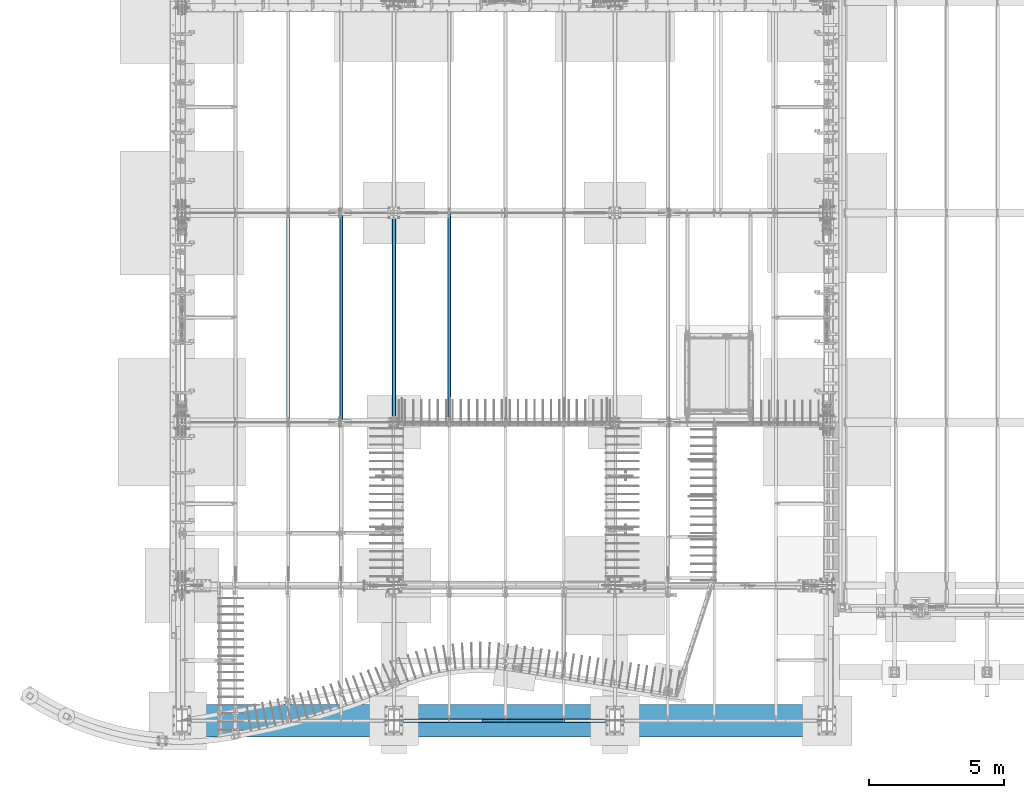
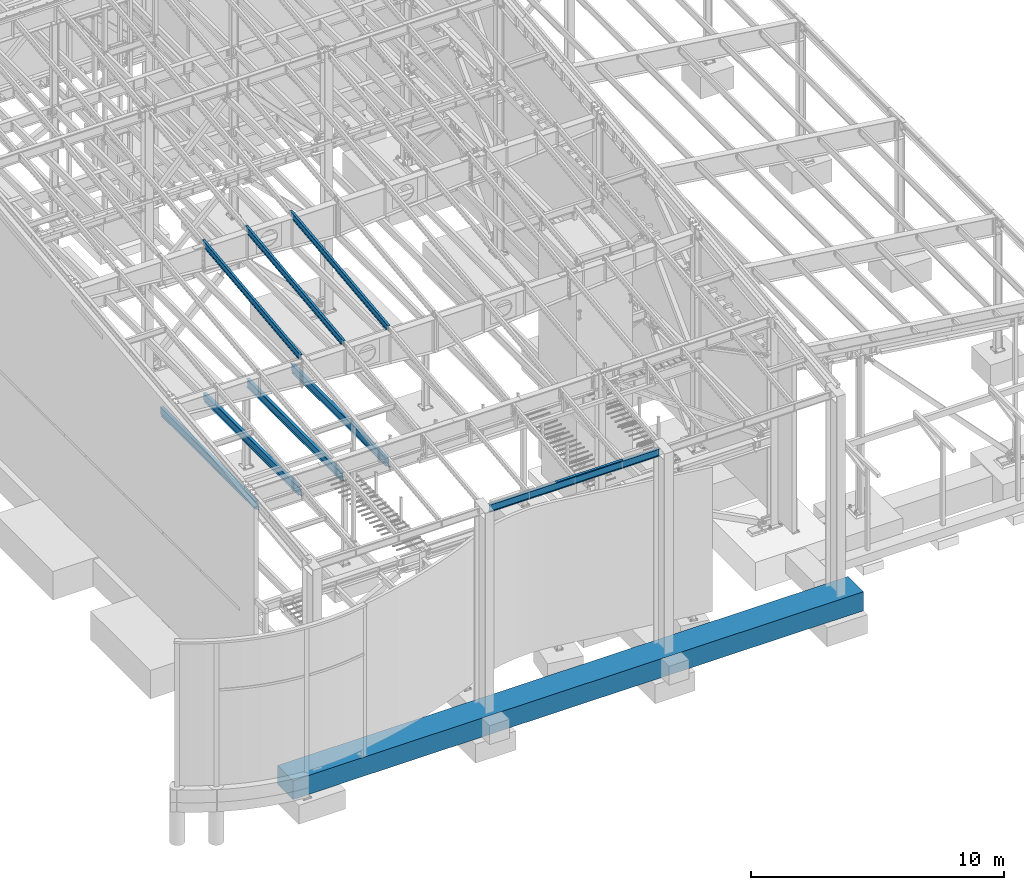
# One storey, part 711 of 1179: 10 beams, 9 elements without a shape of their own.
"""IFC2X3 building model written with IfcOpenShell, lengths in millimetres."""

from ifc_helpers import new_model, si_unit, frame, origin_with_axes, place, context, subcontext, project, spatial, faceted_brep, material, type_object, element, aggregate, save


model = new_model("IFC2X3")

# Units and contexts
model_context = context("Model", 3, precision=1e-05, world=origin_with_axes())
body_context = subcontext(model_context, "Body", "Model", "MODEL_VIEW")
ifc_project = project(units=[si_unit("LENGTHUNIT", "METRE", prefix="MILLI"), si_unit("AREAUNIT", "SQUARE_METRE"), si_unit("VOLUMEUNIT", "CUBIC_METRE"), si_unit("MASSUNIT", "GRAM", prefix="KILO"), si_unit("TIMEUNIT", "SECOND"), si_unit("PLANEANGLEUNIT", "RADIAN"), si_unit("SOLIDANGLEUNIT", "STERADIAN"), si_unit("THERMODYNAMICTEMPERATUREUNIT", "DEGREE_CELSIUS"), si_unit("LUMINOUSINTENSITYUNIT", "LUMEN")], contexts=[model_context])

# Site, building, storey
site_placement = place(None, origin_with_axes())
site = spatial("IfcSite", under=ifc_project, at=site_placement, CompositionType="ELEMENT")
building_placement = place(site_placement, origin_with_axes())
building = spatial("IfcBuilding", under=site, at=building_placement, Name="Undefined", CompositionType="ELEMENT")
storey_placement = place(building_placement, origin_with_axes())
storey = spatial("IfcBuildingStorey", under=building, at=storey_placement, Name="Undefined", CompositionType="ELEMENT", Elevation=0.0)

# Assembly, beam
assembly_1_placement = place(storey_placement, origin_with_axes())
assembly_1 = element("IfcElementAssembly", 1, at=assembly_1_placement, inside=storey, Name="BEAM", AssemblyPlace="NOTDEFINED", PredefinedType="RIGID_FRAME")
ifc_material_1 = material(Name="STEEL/A992")
beam_type_1 = type_object("IfcBeamType", Name="W14X22", PredefinedType="NOTDEFINED")
beam_1_placement = place(assembly_1_placement, frame((8280.4, 438.14999988271, 9090.62031305009), z_axis=(0.0, 0.0, 1.0), x_axis=(1.0, 0.0, 0.0)))
beam_1 = element("IfcBeam", 2, at=beam_1_placement, type_object=beam_type_1, material=ifc_material_1, Name="BEAM", ObjectType="W14X22", context=body_context, shape_type="Brep", body=[
    faceted_brep([(212.725000000002, -63.5, -174.625), (212.725000000002, 63.5, -174.625), (7966.07500000001, 63.5, -174.625), (7966.07500000001, -63.5, -174.625), (212.725000000002, -63.5, -166.6875), (212.725000000002, -3.17500000000001, -166.6875), (212.725000000002, -3.17500000000001, 166.6875), (212.725000000002, -63.5, 166.6875), (212.725000000002, -63.5, 174.625), (212.725000000002, 63.5, 174.625), (212.725000000002, 63.5, 166.6875), (212.725000000002, 3.17500000000001, 166.6875), (212.725000000002, 3.17500000000001, 137.265000000092), (212.725000000002, 3.17500000000001, -92.8149999999841), (212.725000000002, 3.17500000000001, -166.6875), (212.725000000002, 63.5, -166.6875), (7966.07500000001, -63.5, -166.6875), (7966.07500000001, -3.17500000000001, -166.6875), (7966.07500000001, -3.17500000000001, 166.6875), (7966.07500000001, -63.5, 166.6875), (7966.07500000001, -63.5, 174.625), (7966.07500000001, 63.5, 174.625), (7966.07500000001, 63.5, 166.6875), (7966.07500000001, 3.17500000000001, 166.6875), (7966.07500000001, 3.17500000000001, 137.265000000094), (7966.07500000001, 3.17500000000001, -92.8149999999823), (7966.07500000001, 3.17500000000001, -166.6875), (7966.07500000001, 63.5, -166.6875)], [[[0, 1, 2, 3]], [[0, 4, 5, 6, 7, 8, 9, 10, 11, 12, 13, 14, 15, 1]], [[5, 4, 16, 17]], [[6, 5, 17, 18]], [[7, 6, 18, 19]], [[8, 7, 19, 20]], [[9, 8, 20, 21]], [[10, 9, 21, 22]], [[11, 10, 22, 23]], [[14, 13, 12, 11, 23, 24, 25, 26]], [[15, 14, 26, 27]], [[1, 15, 27, 2]], [[26, 25, 24, 23, 22, 21, 20, 19, 18, 17, 16, 3, 2, 27]], [[4, 0, 3, 16]]]),
])

assembly_2_placement = place(storey_placement, origin_with_axes())
assembly_2 = element("IfcElementAssembly", 3, at=assembly_2_placement, inside=storey, Name="BEAM", AssemblyPlace="NOTDEFINED", PredefinedType="RIGID_FRAME")
beam_type_2 = type_object("IfcBeamType", Name="W16X31", PredefinedType="NOTDEFINED")
beam_2_placement = place(assembly_2_placement, frame((10325.1001686096, 11480.8, 3900.4875), z_axis=(0.0, 0.0, 1.0), x_axis=(0.0, 1.0, 0.0)))
beam_2 = element("IfcBeam", 4, at=beam_2_placement, type_object=beam_type_2, material=ifc_material_1, Name="BEAM", ObjectType="W16X31", context=body_context, shape_type="Brep", body=[
    faceted_brep([(7620.79375, -69.8499999999985, 201.6125), (7620.79375, -69.8499999999985, 190.5), (7620.79375, -3.17499999999927, 190.5), (7620.79375, -3.17499999999927, 182.562499809265), (7620.79375, 3.17499999999927, 182.562499809265), (7620.79375, 3.17499999999927, 190.5), (7620.79375, 69.8499999999985, 190.5), (7620.79375, 69.8499999999985, 201.6125), (7621.76047992259, -3.17499999999927, 177.70242029122), (7621.76047992259, 3.17499999999927, 177.70242029122), (7624.51349382307, -3.17499999999927, 173.582243823066), (7624.51349382307, 3.17499999999927, 173.582243823066), (7628.63367029122, -3.17499999999927, 170.829229922588), (7628.63367029122, 3.17499999999927, 170.829229922588), (7633.49374980927, -3.17499999999927, 169.8625), (7633.49374980927, 3.17499999999927, 169.8625), (7728.74375, -3.17499999999927, 169.8625), (7728.74375, 3.17499999999927, 169.8625), (117.474999999999, -69.8499999999985, 201.6125), (117.474999999999, 69.8499999999985, 201.6125), (117.474999999999, 69.8499999999985, 190.5), (117.474999999999, 3.17499999999927, 190.5), (117.475, 3.17496270443371, 182.562499809265), (117.475, -3.17499999999927, 182.562499809265), (117.474999999999, -3.17499999999927, 190.5), (117.474999999999, -69.8499999999985, 190.5), (116.508270077413, 3.17496584275432, 177.702420291219), (116.508270077413, -3.17499999999927, 177.702420291219), (113.755256176935, 3.17496850329189, 173.582243823066), (113.755256176935, -3.17499999999927, 173.582243823066), (109.635079708782, 3.17497028100843, 170.829229922588), (109.635079708782, -3.17499999999927, 170.829229922588), (104.775000190735, 3.17497090526012, 169.8625), (104.775000190735, -3.17499999999927, 169.8625), (17.4625000000015, 3.17499999999927, 169.8625), (17.4625000000015, -3.17499999999927, 169.8625), (17.4624999999942, 3.17499999999927, -190.5), (17.4624999999942, 3.17549991607666, -201.6125), (17.4624999999942, -69.8499999999985, -201.6125), (17.4624999999942, -69.8499999999985, -190.5), (17.4624999999942, -3.17499999999927, -190.5), (144.462499999994, 3.17549991607666, -190.5), (144.462499999994, 3.17549991607666, -201.6125), (144.462499999994, 69.8499999999985, -190.5), (144.462499999994, 69.8499999999985, -201.6125), (7601.74375, 3.17499999999927, -190.5), (7601.74375, 69.8499999999985, -190.5), (7601.74375, 69.8499999999985, -201.6125), (7601.74375, 3.17561705897606, -201.6125), (7728.74375, 3.17499999999927, -190.5), (7728.74375, 3.17561705897606, -201.6125), (7728.74375, -69.8499999999985, -201.6125), (7728.74375, -69.8499999999985, -190.5), (7728.74375, -3.17499999999927, -190.5)], [[[0, 1, 2, 3, 4, 5, 6, 7]], [[8, 9, 4, 3]], [[10, 11, 9, 8]], [[12, 13, 11, 10]], [[14, 15, 13, 12]], [[16, 17, 15, 14]], [[18, 19, 20, 21, 22, 23, 24, 25]], [[23, 22, 26, 27]], [[27, 26, 28, 29]], [[29, 28, 30, 31]], [[31, 30, 32, 33]], [[33, 32, 34, 35]], [[36, 37, 38, 39, 40, 35, 34]], [[41, 42, 37, 36]], [[43, 44, 42, 41]], [[45, 46, 43, 41]], [[46, 47, 44, 43]], [[45, 48, 47, 46]], [[49, 50, 48, 45]], [[47, 48, 50, 51, 38, 37, 42, 44]], [[39, 38, 51, 52]], [[40, 39, 52, 53]], [[27, 29, 31, 33, 35, 40, 53, 16, 14, 12, 10, 8, 3, 2, 24, 23]], [[2, 1, 25, 24]], [[1, 0, 18, 25]], [[0, 7, 19, 18]], [[7, 6, 20, 19]], [[6, 5, 21, 20]], [[5, 4, 9, 11, 13, 15, 17, 49, 45, 41, 36, 34, 32, 30, 28, 26, 22, 21]], [[53, 52, 51, 50, 49, 17, 16]]]),
])
aggregate(assembly_2, [beam_2])

assembly_3_placement = place(storey_placement, origin_with_axes())
assembly_3 = element("IfcElementAssembly", 5, at=assembly_3_placement, inside=storey, Name="BEAM", AssemblyPlace="NOTDEFINED", PredefinedType="RIGID_FRAME")
beam_3_placement = place(assembly_3_placement, frame((8280.4, 11480.8, 3900.4875), z_axis=(0.0, 0.0, 1.0), x_axis=(0.0, 1.0, 0.0)))
beam_3 = element("IfcBeam", 6, at=beam_3_placement, type_object=beam_type_2, material=ifc_material_1, Name="BEAM", ObjectType="W16X31", context=body_context, shape_type="Brep", body=[
    faceted_brep([(114.299999999999, -69.8500000000004, -190.5), (114.299999999999, -69.8500000000004, -201.6125), (7632.7, -69.8500000000004, -201.6125), (7632.7, -69.8500000000004, -190.5), (114.299999999999, -3.17499999999927, -190.5), (7632.7, -3.17499999999927, -190.5), (114.299999999999, -3.17499999999927, 190.5), (7632.7, -3.17499999999927, 190.5), (114.299999999999, -69.8500000000004, 190.5), (7632.7, -69.8500000000004, 190.5), (114.299999999999, -69.8500000000004, 201.6125), (7632.7, -69.8500000000004, 201.6125), (114.299999999999, 69.8500000000004, 201.6125), (7632.7, 69.8500000000004, 201.6125), (114.299999999999, 69.8500000000004, 190.5), (7632.7, 69.8500000000004, 190.5), (114.299999999999, 3.17499999999927, 190.5), (7632.7, 3.17499999999927, 190.5), (114.299999999999, 3.17499999999927, -190.5), (7632.7, 3.17499999999927, 164.252500725411), (7632.7, 3.17499999999927, -142.0275032968), (7632.7, 3.17499999999927, -190.5), (114.299999999999, 69.8500000000004, -190.5), (7632.7, 69.8500000000004, -190.5), (114.299999999999, 69.8500000000004, -201.6125), (7632.7, 69.8500000000004, -201.6125)], [[[0, 1, 2, 3]], [[4, 0, 3, 5]], [[6, 4, 5, 7]], [[8, 6, 7, 9]], [[10, 8, 9, 11]], [[12, 10, 11, 13]], [[14, 12, 13, 15]], [[16, 14, 15, 17]], [[18, 16, 17, 19, 20, 21]], [[22, 18, 21, 23]], [[1, 0, 4, 6, 8, 10, 12, 14, 16, 18, 22, 24]], [[1, 24, 25, 2]], [[21, 20, 19, 17, 15, 13, 11, 9, 7, 5, 3, 2, 25, 23]], [[24, 22, 23, 25]]]),
])
aggregate(assembly_3, [beam_3])

assembly_4_placement = place(storey_placement, origin_with_axes())
assembly_4 = element("IfcElementAssembly", 7, at=assembly_4_placement, inside=storey, Name="BEAM", AssemblyPlace="NOTDEFINED", PredefinedType="RIGID_FRAME")
beam_4_placement = place(assembly_4_placement, frame((6324.59996643066, 11480.8, 3900.4875), z_axis=(0.0, 0.0, 1.0), x_axis=(0.0, 1.0, 0.0)))
beam_4 = element("IfcBeam", 8, at=beam_4_placement, type_object=beam_type_2, material=ifc_material_1, Name="BEAM", ObjectType="W16X31", context=body_context, shape_type="Brep", body=[
    faceted_brep([(104.775000190735, -3.17499999999927, 169.8625), (104.775000190735, 3.17497090526012, 169.8625), (17.4625000000015, 3.17499999999927, 169.8625), (17.4625000000015, -3.17499999999927, 169.8625), (109.635079708782, -3.17499999999927, 170.829229922588), (109.635079708782, 3.17497028100843, 170.829229922588), (113.755256176935, -3.17499999999927, 173.582243823066), (113.755256176935, 3.17496850329189, 173.582243823066), (116.508270077413, -3.17499999999927, 177.702420291219), (116.508270077413, 3.17496584275432, 177.702420291219), (117.475, -3.17499999999927, 182.562499809265), (117.475, 3.17496270443371, 182.562499809265), (117.474999999999, -69.8499999999985, 201.6125), (117.474999999999, 69.8499999999985, 201.6125), (117.474999999999, 69.8499999999985, 190.5), (117.474999999999, 3.17499999999927, 190.5), (117.474999999999, -3.17499999999927, 190.5), (117.474999999999, -69.8499999999985, 190.5), (7601.74375, 3.17499999999927, -190.5), (7601.74375, 69.8499999999985, -190.5), (144.462499999994, 69.8499999999985, -190.5), (144.462499999994, 3.17549991607666, -190.5), (17.4624999999942, -3.17499999999927, -190.5), (17.4624999999942, -69.8499999999985, -190.5), (7728.74375, -69.8499999999985, -190.5), (7728.74375, -3.17499999999927, -190.5), (17.4624999999942, -69.8499999999985, -201.6125), (7728.74375, -69.8499999999985, -201.6125), (7601.74375, 69.8499999999985, -201.6125), (7601.74375, 3.17561705897606, -201.6125), (7728.74375, 3.17561705897606, -201.6125), (17.4624999999942, 3.17549991607666, -201.6125), (144.462499999994, 3.17549991607666, -201.6125), (144.462499999994, 69.8499999999985, -201.6125), (17.4624999999942, 3.17499999999927, -190.5), (7728.74375, 3.17499999999927, -190.5), (7728.74375, 3.17499999999927, 169.8625), (7728.74375, -3.17499999999927, 169.8625), (7633.49374980927, 3.17499999999927, 169.8625), (7633.49374980927, -3.17499999999927, 169.8625), (7628.63367029122, 3.17499999999927, 170.829229922588), (7628.63367029122, -3.17499999999927, 170.829229922588), (7624.51349382307, 3.17499999999927, 173.582243823066), (7624.51349382307, -3.17499999999927, 173.582243823066), (7621.76047992259, 3.17499999999927, 177.70242029122), (7621.76047992259, -3.17499999999927, 177.70242029122), (7620.79375, 3.17499999999927, 182.562499809265), (7620.79375, -3.17499999999927, 182.562499809265), (7620.79375, -69.8499999999985, 201.6125), (7620.79375, -69.8499999999985, 190.5), (7620.79375, -3.17499999999927, 190.5), (7620.79375, 3.17499999999927, 190.5), (7620.79375, 69.8499999999985, 190.5), (7620.79375, 69.8499999999985, 201.6125)], [[[0, 1, 2, 3]], [[4, 5, 1, 0]], [[6, 7, 5, 4]], [[8, 9, 7, 6]], [[10, 11, 9, 8]], [[12, 13, 14, 15, 11, 10, 16, 17]], [[18, 19, 20, 21]], [[22, 23, 24, 25]], [[23, 26, 27, 24]], [[28, 29, 30, 27, 26, 31, 32, 33]], [[21, 32, 31, 34]], [[20, 33, 32, 21]], [[19, 28, 33, 20]], [[18, 29, 28, 19]], [[35, 30, 29, 18]], [[25, 24, 27, 30, 35, 36, 37]], [[37, 36, 38, 39]], [[39, 38, 40, 41]], [[41, 40, 42, 43]], [[43, 42, 44, 45]], [[45, 44, 46, 47]], [[48, 49, 50, 47, 46, 51, 52, 53]], [[49, 48, 12, 17]], [[50, 49, 17, 16]], [[8, 6, 4, 0, 3, 22, 25, 37, 39, 41, 43, 45, 47, 50, 16, 10]], [[34, 31, 26, 23, 22, 3, 2]], [[51, 46, 44, 42, 40, 38, 36, 35, 18, 21, 34, 2, 1, 5, 7, 9, 11, 15]], [[52, 51, 15, 14]], [[53, 52, 14, 13]], [[48, 53, 13, 12]]]),
])
aggregate(assembly_4, [beam_4])

assembly_5_placement = place(storey_placement, origin_with_axes())
assembly_5 = element("IfcElementAssembly", 9, at=assembly_5_placement, inside=storey, Name="BEAM", AssemblyPlace="NOTDEFINED", PredefinedType="RIGID_FRAME")
beam_5_placement = place(assembly_5_placement, frame((4368.8, 11480.8, 3900.4875), z_axis=(0.0, 0.0, 1.0), x_axis=(0.0, 1.0, 0.0)))
beam_5 = element("IfcBeam", 10, at=beam_5_placement, type_object=beam_type_2, material=ifc_material_1, Name="BEAM", ObjectType="W16X31", context=body_context, shape_type="Brep", body=[
    faceted_brep([(104.775000190735, -3.17499999999927, 169.8625), (104.775000190735, 3.17497090526012, 169.8625), (17.4625000000015, 3.17499999999927, 169.8625), (17.4625000000015, -3.17499999999927, 169.8625), (109.635079708782, -3.17499999999927, 170.829229922588), (109.635079708782, 3.17497028100843, 170.829229922588), (113.755256176935, -3.17499999999927, 173.582243823066), (113.755256176935, 3.17496850329189, 173.582243823066), (116.508270077413, -3.17499999999927, 177.702420291219), (116.508270077413, 3.17496584275432, 177.702420291219), (117.475, -3.17499999999927, 182.562499809265), (117.475, 3.17496270443371, 182.562499809265), (117.474999999999, -69.8499999999985, 201.6125), (117.474999999999, 69.8499999999985, 201.6125), (117.474999999999, 69.8499999999985, 190.5), (117.474999999999, 3.17499999999927, 190.5), (117.474999999999, -3.17499999999927, 190.5), (117.474999999999, -69.8499999999985, 190.5), (7601.74375, 3.17499999999927, -190.5), (7601.74375, 69.8499999999985, -190.5), (144.462499999994, 69.8499999999985, -190.5), (144.462499999994, 3.17549991607666, -190.5), (17.4624999999942, -3.17499999999927, -190.5), (17.4624999999942, -69.8499999999985, -190.5), (7728.74375, -69.8499999999985, -190.5), (7728.74375, -3.17499999999927, -190.5), (17.4624999999942, -69.8499999999985, -201.6125), (7728.74375, -69.8499999999985, -201.6125), (7601.74375, 69.8499999999985, -201.6125), (7601.74375, 3.17561705897606, -201.6125), (7728.74375, 3.17561705897606, -201.6125), (17.4624999999942, 3.17549991607666, -201.6125), (144.462499999994, 3.17549991607666, -201.6125), (144.462499999994, 69.8499999999985, -201.6125), (17.4624999999942, 3.17499999999927, -190.5), (7728.74375, 3.17499999999927, -190.5), (7728.74375, 3.17499999999927, 169.8625), (7728.74375, -3.17499999999927, 169.8625), (7633.49374980927, 3.17499999999927, 169.8625), (7633.49374980927, -3.17499999999927, 169.8625), (7628.63367029122, 3.17499999999927, 170.829229922588), (7628.63367029122, -3.17499999999927, 170.829229922588), (7624.51349382307, 3.17499999999927, 173.582243823066), (7624.51349382307, -3.17499999999927, 173.582243823066), (7621.76047992259, 3.17499999999927, 177.70242029122), (7621.76047992259, -3.17499999999927, 177.70242029122), (7620.79375, 3.17499999999927, 182.562499809265), (7620.79375, -3.17499999999927, 182.562499809265), (7620.79375, -69.8499999999985, 201.6125), (7620.79375, -69.8499999999985, 190.5), (7620.79375, -3.17499999999927, 190.5), (7620.79375, 3.17499999999927, 190.5), (7620.79375, 69.8499999999985, 190.5), (7620.79375, 69.8499999999985, 201.6125)], [[[0, 1, 2, 3]], [[4, 5, 1, 0]], [[6, 7, 5, 4]], [[8, 9, 7, 6]], [[10, 11, 9, 8]], [[12, 13, 14, 15, 11, 10, 16, 17]], [[18, 19, 20, 21]], [[22, 23, 24, 25]], [[23, 26, 27, 24]], [[28, 29, 30, 27, 26, 31, 32, 33]], [[21, 32, 31, 34]], [[20, 33, 32, 21]], [[19, 28, 33, 20]], [[18, 29, 28, 19]], [[35, 30, 29, 18]], [[25, 24, 27, 30, 35, 36, 37]], [[37, 36, 38, 39]], [[39, 38, 40, 41]], [[41, 40, 42, 43]], [[43, 42, 44, 45]], [[45, 44, 46, 47]], [[48, 49, 50, 47, 46, 51, 52, 53]], [[49, 48, 12, 17]], [[50, 49, 17, 16]], [[8, 6, 4, 0, 3, 22, 25, 37, 39, 41, 43, 45, 47, 50, 16, 10]], [[34, 31, 26, 23, 22, 3, 2]], [[51, 46, 44, 42, 40, 38, 36, 35, 18, 21, 34, 2, 1, 5, 7, 9, 11, 15]], [[52, 51, 15, 14]], [[53, 52, 14, 13]], [[48, 53, 13, 12]]]),
])
aggregate(assembly_5, [beam_5])

# Beam
ifc_material_2 = material(Name="STEEL/A36")
beam_type_3 = type_object("IfcBeamType", PredefinedType="NOTDEFINED")
beam_6_placement = place(assembly_1_placement, frame((13065.1249999995, 485.774999119673, 9265.24531303919), z_axis=(-1.0, 0.0, 0.0), x_axis=(0.0, 0.0, 1.0)))
beam_6 = element("IfcBeam", 11, at=beam_6_placement, type_object=beam_type_3, material=ifc_material_2, Name="BENT_PLATE", context=body_context, shape_type="Brep", body=[
    faceted_brep([(0.0, -3.17499999999927, -1524.0), (6.00266503170133e-10, -3.17499999922438, 1524.00000000052), (6.00266503170133e-10, 3.17500000077416, 1524.00000000052), (0.0, 3.17499999999927, -1524.0), (36.8806648358295, 3.17499999974928, 1524.0), (36.8806648358295, 3.17499999974928, -1524.0), (29.7727112184712, -3.17500000020243, -1524.0), (29.7727112184712, -3.17500000020243, 1524.0), (25.3999996289767, -98.4249984738682, 1524.0), (25.3999996289767, -98.4249984738682, -1524.0), (19.7271291840298, -92.0749984738682, -1524.0), (19.7271291840298, -92.0749984738682, 1524.0), (2.13476596400142e-08, -98.4249984738682, 1524.0), (2.13476596400142e-08, -98.4249984738682, -1524.0), (2.13476596400142e-08, -92.0749984738682, 1524.0), (2.13476596400142e-08, -92.0749984738682, -1524.0)], [[[0, 1, 2, 3]], [[3, 2, 4, 5]], [[1, 0, 6, 7]], [[5, 4, 8, 9]], [[7, 6, 10, 11]], [[9, 8, 12, 13]], [[8, 4, 2, 1, 7, 11, 14, 12]], [[11, 10, 15, 14]], [[10, 6, 0, 3, 5, 9, 13, 15]], [[14, 15, 13, 12]]]),
])

aggregate(assembly_1, [beam_6, beam_1])

# Assembly, beam
assembly_6_placement = place(storey_placement, origin_with_axes())
assembly_6 = element("IfcElementAssembly", 12, at=assembly_6_placement, inside=storey, Name="BEAM", AssemblyPlace="NOTDEFINED", PredefinedType="RIGID_FRAME")
beam_type_4 = type_object("IfcBeamType", Name="W12X22", PredefinedType="NOTDEFINED")
beam_7_placement = place(assembly_6_placement, frame((10325.1, 11498.2779321842, 10389.6051906331), z_axis=(0.0, -0.112284087038017, 0.993676146336441), x_axis=(0.0, 0.993676146336441, 0.112284087038017)))
beam_7 = element("IfcBeam", 13, at=beam_7_placement, type_object=beam_type_4, material=ifc_material_1, Name="BEAM", ObjectType="W12X22", context=body_context, shape_type="Brep", body=[
    faceted_brep([(7583.46730043383, -3.17499999999927, -144.462500002994), (7583.46730043383, -50.7999999999993, -144.462500002994), (7582.21160266769, -50.7999999999993, -155.575000002988), (7582.21160266769, 50.7999999999993, -155.575000002988), (7583.46730043383, 50.7999999999993, -144.462500002994), (7583.46730043383, 3.17499999999927, -144.462500002994), (7586.83832669432, 3.17499999999927, -114.630059163946), (7586.83832669432, -3.17499999999927, -114.630059163946), (7588.34465274973, 3.17499999999927, -109.909262464753), (7588.34465274973, -3.17499999999927, -109.909262464753), (7591.54288724583, 3.17499999999927, -106.124261042249), (7591.54288724583, -3.17499999999927, -106.124261042249), (7595.94612797272, 3.17499999999927, -103.851287051781), (7595.94612797272, -3.17499999999927, -103.851287051781), (7600.88402144536, 3.17499999999927, -103.436380178771), (7600.88402144536, -3.17499999999927, -103.436380178771), (7758.6208335002, -3.17499999999927, -121.260430776909), (7758.62083354224, 3.17499999999927, -121.26043078166), (6.38101702707718, -50.7999999999993, 155.574999999912), (5.12531926095107, -50.7999999999993, 144.46249999992), (7788.64717240277, -50.7999999999993, 144.462499996762), (7789.9028701689, -50.7999999999993, 155.574999996754), (6.38101702707718, 50.7999999999993, 155.574999999912), (7789.9028701689, 50.7999999999993, 155.574999996754), (5.12531926095107, 50.7999999999993, 144.46249999992), (7788.64717240277, 50.7999999999993, 144.462499996762), (5.12531926095107, 3.17499999999927, 144.46249999992), (7788.64717240277, 3.17499999999927, 144.462499996762), (145.30344487597, -3.17499999999927, -142.022226300664), (145.30344487597, 3.17499999999927, -142.022226300664), (145.027696926005, 3.17499999999927, -144.462499999976), (145.027696926005, 50.7999999999993, -144.462499999976), (143.771999161854, 50.7999999999993, -155.574999999972), (143.771999161854, -50.7999999999993, -155.574999999972), (145.027696926005, -50.7999999999993, -144.462499999976), (145.027696926005, -3.17499999999927, -144.462499999976), (-25.0716067072917, -3.17499999999927, -122.770071196437), (-25.0716067072917, 3.17499999999927, -122.770071196437), (5.12531926095107, -3.17499999999927, 144.46249999992), (7788.64717240277, -3.17499999999927, 144.462499996762)], [[[0, 1, 2, 3, 4, 5, 6, 7]], [[7, 6, 8, 9]], [[9, 8, 10, 11]], [[11, 10, 12, 13]], [[13, 12, 14, 15]], [[16, 15, 14, 17]], [[18, 19, 20, 21]], [[22, 18, 21, 23]], [[24, 22, 23, 25]], [[26, 24, 25, 27]], [[28, 29, 30, 31, 32, 33, 34, 35]], [[36, 37, 29, 28]], [[38, 19, 18, 22, 24, 26, 37, 36]], [[19, 38, 39, 20]], [[27, 25, 23, 21, 20, 39, 16, 17]], [[12, 10, 8, 6, 5, 30, 29, 37, 26, 27, 17, 14]], [[31, 30, 5, 4]], [[32, 31, 4, 3]], [[33, 32, 3, 2]], [[34, 33, 2, 1]], [[35, 34, 1, 0]], [[39, 38, 36, 28, 35, 0, 7, 9, 11, 13, 15, 16]]]),
])
aggregate(assembly_6, [beam_7])

assembly_7_placement = place(storey_placement, origin_with_axes())
assembly_7 = element("IfcElementAssembly", 14, at=assembly_7_placement, inside=storey, Name="BEAM", AssemblyPlace="NOTDEFINED", PredefinedType="RIGID_FRAME")
beam_8_placement = place(assembly_7_placement, frame((8280.4, 11498.2779321842, 10389.6051906331), z_axis=(0.0, -0.112284087038017, 0.993676146336441), x_axis=(0.0, 0.993676146336441, 0.112284087038017)))
beam_8 = element("IfcBeam", 15, at=beam_8_placement, type_object=beam_type_4, material=ifc_material_1, Name="BEAM", ObjectType="W12X22", context=body_context, shape_type="Brep", body=[
    faceted_brep([(7583.46730043383, -3.17499999999927, -144.462500002994), (7583.46730043383, -50.7999999999993, -144.462500002994), (7582.21160266769, -50.7999999999993, -155.575000002988), (7582.21160266769, 50.7999999999993, -155.575000002988), (7583.46730043383, 50.7999999999993, -144.462500002994), (7583.46730043383, 3.17499999999927, -144.462500002994), (7586.83832669432, 3.17499999999927, -114.630059163946), (7586.83832669432, -3.17499999999927, -114.630059163946), (7588.34465274973, 3.17499999999927, -109.909262464753), (7588.34465274973, -3.17499999999927, -109.909262464753), (7591.54288724583, 3.17499999999927, -106.124261042249), (7591.54288724583, -3.17499999999927, -106.124261042249), (7595.94612797272, 3.17499999999927, -103.851287051781), (7595.94612797272, -3.17499999999927, -103.851287051781), (7600.88402144536, 3.17499999999927, -103.436380178771), (7600.88402144536, -3.17499999999927, -103.436380178771), (7758.6208335002, -3.17499999999927, -121.260430776909), (7758.62083354224, 3.17499999999927, -121.26043078166), (6.38101702707718, -50.7999999999993, 155.574999999912), (5.12531926095107, -50.7999999999993, 144.46249999992), (7788.64717240277, -50.7999999999993, 144.462499996762), (7789.9028701689, -50.7999999999993, 155.574999996754), (6.38101702707718, 50.7999999999993, 155.574999999912), (7789.9028701689, 50.7999999999993, 155.574999996754), (5.12531926095107, 50.7999999999993, 144.46249999992), (7788.64717240277, 50.7999999999993, 144.462499996762), (5.12531926095107, 3.17499999999927, 144.46249999992), (7788.64717240277, 3.17499999999927, 144.462499996762), (145.30344487597, -3.17499999999927, -142.022226300664), (145.30344487597, 3.17499999999927, -142.022226300664), (145.027696926005, 3.17499999999927, -144.462499999976), (145.027696926005, 50.7999999999993, -144.462499999976), (143.771999161854, 50.7999999999993, -155.574999999972), (143.771999161854, -50.7999999999993, -155.574999999972), (145.027696926005, -50.7999999999993, -144.462499999976), (145.027696926005, -3.17499999999927, -144.462499999976), (-25.0716067072917, -3.17499999999927, -122.770071196437), (-25.0716067072917, 3.17499999999927, -122.770071196437), (5.12531926095107, -3.17499999999927, 144.46249999992), (7788.64717240277, -3.17499999999927, 144.462499996762)], [[[0, 1, 2, 3, 4, 5, 6, 7]], [[7, 6, 8, 9]], [[9, 8, 10, 11]], [[11, 10, 12, 13]], [[13, 12, 14, 15]], [[16, 15, 14, 17]], [[18, 19, 20, 21]], [[22, 18, 21, 23]], [[24, 22, 23, 25]], [[26, 24, 25, 27]], [[28, 29, 30, 31, 32, 33, 34, 35]], [[36, 37, 29, 28]], [[38, 19, 18, 22, 24, 26, 37, 36]], [[19, 38, 39, 20]], [[27, 25, 23, 21, 20, 39, 16, 17]], [[12, 10, 8, 6, 5, 30, 29, 37, 26, 27, 17, 14]], [[31, 30, 5, 4]], [[32, 31, 4, 3]], [[33, 32, 3, 2]], [[34, 33, 2, 1]], [[35, 34, 1, 0]], [[39, 38, 36, 28, 35, 0, 7, 9, 11, 13, 15, 16]]]),
])
aggregate(assembly_7, [beam_8])

assembly_8_placement = place(storey_placement, origin_with_axes())
assembly_8 = element("IfcElementAssembly", 16, at=assembly_8_placement, inside=storey, Name="BEAM", AssemblyPlace="NOTDEFINED", PredefinedType="RIGID_FRAME")
beam_9_placement = place(assembly_8_placement, frame((6324.6, 11498.2779321842, 10389.6051906331), z_axis=(0.0, -0.112284087038017, 0.993676146336441), x_axis=(0.0, 0.993676146336441, 0.112284087038017)))
beam_9 = element("IfcBeam", 17, at=beam_9_placement, type_object=beam_type_4, material=ifc_material_1, Name="BEAM", ObjectType="W12X22", context=body_context, shape_type="Brep", body=[
    faceted_brep([(7577.0768884033, -3.17499999999927, -144.46250000299), (7577.0768884033, -50.7999999999993, -144.46250000299), (7575.82119063717, -50.7999999999993, -155.575000002984), (7575.82119063717, 50.7999999999993, -155.575000002984), (7577.0768884033, 50.7999999999993, -144.46250000299), (7577.0768884033, 3.17499999999927, -144.46250000299), (7581.95449107047, 3.17499999999927, -101.29736815286), (7581.95449107047, -3.17499999999927, -101.29736815286), (7583.46081712589, 3.17499999999927, -96.5765714536519), (7583.46081712589, -3.17499999999927, -96.5765714536519), (7586.659051622, 3.17499999999927, -92.7915700311405), (7586.659051622, -3.17499999999927, -92.7915700311405), (7591.06229234892, 3.17499999999927, -90.5185960406798), (7591.06229234892, -3.17499999999927, -90.5185960406798), (7596.00018582157, 3.17499999999927, -90.103689167694), (7596.00018582157, -3.17499999999927, -90.103689167694), (7760.04684140558, -3.17499999999927, -108.640743718448), (7760.04684144763, 3.17499999999927, -108.640743723199), (6.91917347046729, -50.8000000000002, 155.574999999913), (5.66347570433936, -50.8000000000002, 144.46249999992), (7788.64717240277, -50.7999999999993, 144.462499996762), (7789.9028701689, -50.7999999999993, 155.574999996754), (6.91917347046729, 50.8000000000002, 155.574999999913), (7789.9028701689, 50.7999999999993, 155.574999996754), (5.66347570433936, 50.8000000000002, 144.46249999992), (7788.64717240277, 50.7999999999993, 144.462499996762), (5.66347570433936, 3.17500000000018, 144.46249999992), (7788.64717240277, 3.17499999999927, 144.462499996762), (152.144659676069, -3.17500000000018, -142.795274392507), (152.144659676069, 3.17500000000018, -142.795274392507), (151.956265393143, 3.17500000000018, -144.462499999978), (151.956265393143, 50.8000000000002, -144.462499999978), (150.700567628142, 50.8000000000002, -155.574999999973), (150.700567628142, -50.8000000000002, -155.574999999973), (151.956265393143, -50.8000000000002, -144.462499999978), (151.956265393143, -3.17500000000018, -144.462499999978), (151.729752804133, -3.17500000000018, -137.857380922762), (151.729752804133, 3.17500000000018, -137.857380922762), (149.456778816806, -3.17500000000018, -133.454140197582), (149.456778816806, 3.17500000000018, -133.454140197582), (145.671777398622, -3.17500000000018, -130.255905700971), (145.671777398622, 3.17500000000018, -130.255905700971), (140.950980703579, -3.17500000000018, -128.749579642303), (140.950980703579, 3.17500000000018, -128.749579642303), (-23.1142275469101, -3.17500000000018, -110.21042847508), (-23.1142275469101, 3.17500000000018, -110.21042847508), (5.66347570433936, -3.17500000000018, 144.46249999992), (7788.64717240277, -3.17499999999927, 144.462499996762)], [[[0, 1, 2, 3, 4, 5, 6, 7]], [[7, 6, 8, 9]], [[9, 8, 10, 11]], [[11, 10, 12, 13]], [[13, 12, 14, 15]], [[16, 15, 14, 17]], [[18, 19, 20, 21]], [[22, 18, 21, 23]], [[24, 22, 23, 25]], [[26, 24, 25, 27]], [[28, 29, 30, 31, 32, 33, 34, 35]], [[36, 37, 29, 28]], [[38, 39, 37, 36]], [[40, 41, 39, 38]], [[42, 43, 41, 40]], [[44, 45, 43, 42]], [[46, 19, 18, 22, 24, 26, 45, 44]], [[19, 46, 47, 20]], [[27, 25, 23, 21, 20, 47, 16, 17]], [[12, 10, 8, 6, 5, 30, 29, 37, 39, 41, 43, 45, 26, 27, 17, 14]], [[31, 30, 5, 4]], [[32, 31, 4, 3]], [[33, 32, 3, 2]], [[34, 33, 2, 1]], [[35, 34, 1, 0]], [[47, 46, 44, 42, 40, 38, 36, 28, 35, 0, 7, 9, 11, 13, 15, 16]]]),
])
aggregate(assembly_8, [beam_9])

assembly_9_placement = place(storey_placement, origin_with_axes())
assembly_9 = element("IfcElementAssembly", 18, at=assembly_9_placement, inside=storey, Name="GRADE_BEAM", AssemblyPlace="NOTDEFINED", PredefinedType="REINFORCEMENT_UNIT")
ifc_material_3 = material(Name="CONCRETE/5000")
beam_type_5 = type_object("IfcBeamType", PredefinedType="NOTDEFINED")
beam_10_placement = place(assembly_9_placement, frame((-787.399999999998, 438.15, -889.0), z_axis=(0.0, 0.0, 1.0), x_axis=(1.0, 0.0, 0.0)))
beam_10 = element("IfcBeam", 19, at=beam_10_placement, type_object=beam_type_5, material=ifc_material_3, Name="GRADE_BEAM", context=body_context, shape_type="Brep", body=[
    faceted_brep([(0.0, 609.6, -457.2), (0.0, 609.6, 457.2), (26009.6, 609.6, 457.2), (26009.6, 609.6, -457.2), (0.0, -609.6, 457.2), (26009.6, -609.6, 457.2), (0.0, -609.6, -457.2), (26009.6, -609.6, -457.2)], [[[0, 1, 2, 3]], [[1, 4, 5, 2]], [[4, 6, 7, 5]], [[6, 0, 3, 7]], [[5, 7, 3, 2]], [[6, 4, 1, 0]]]),
])
aggregate(assembly_9, [beam_10])

save(model, "model.ifc")
